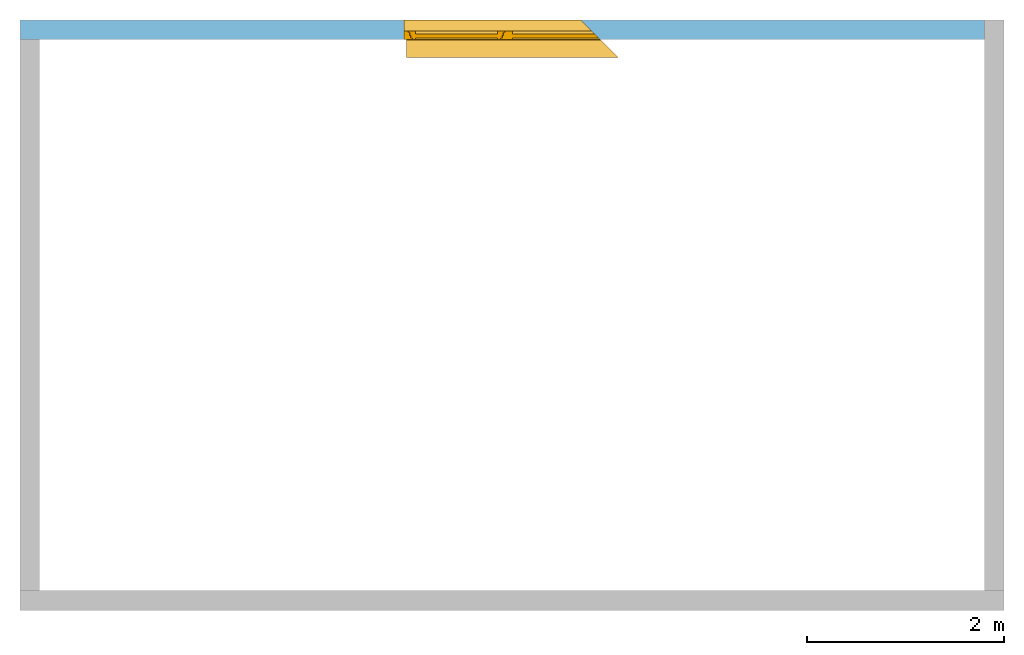
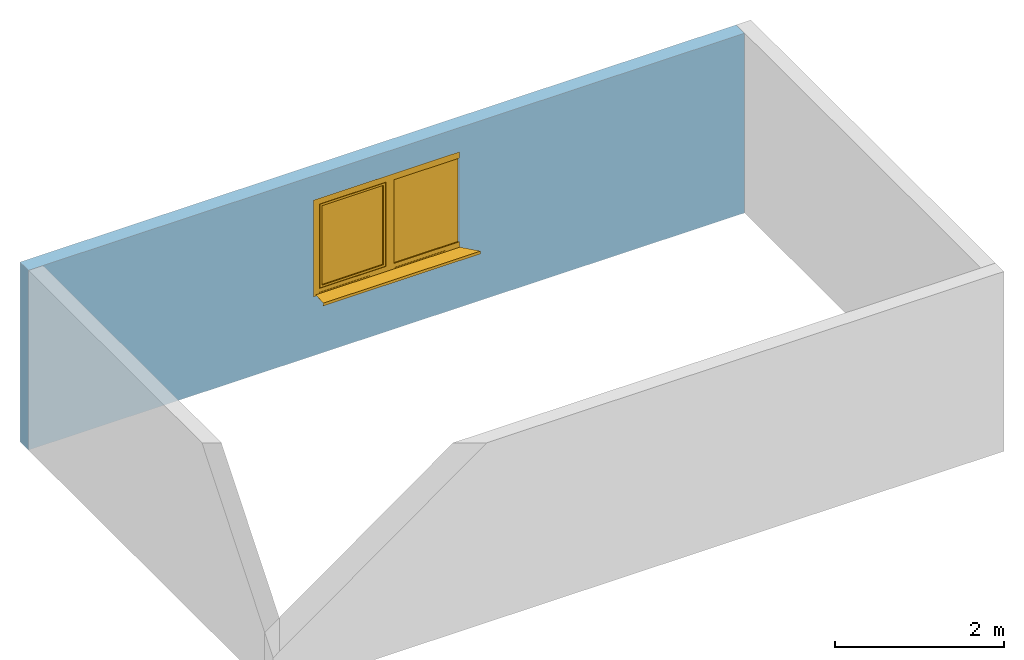
# One storey, part 2 of 2: 1 window, 1 opening, plus 1 element that does not belong to this part.
"""IFC2X3 building model written with IfcOpenShell, lengths in metres."""

from ifc_helpers import new_model, entity, si_unit, converted_unit, derived_unit, direction, frame, frame_2d, origin, place, context, subcontext, project, spatial, rectangle, extrude, faceted_brep, source, transform, mapped, material, material_list, layer, layer_set, layer_usage, type_object, type_shapes, element, fill, save


model = new_model("IFC2X3")

# Units and contexts
model_context = context("Model", 3, precision=1e-05, world=origin(), true_north=direction((6.12303176911189e-17, 1.0)))
body_context = subcontext(model_context, "Body", "Model", "MODEL_VIEW")
ifc_project = project(units=[si_unit("LENGTHUNIT", "METRE"), si_unit("AREAUNIT", "SQUARE_METRE"), si_unit("VOLUMEUNIT", "CUBIC_METRE"), converted_unit("PLANEANGLEUNIT", "DEGREE", entity("IfcRatioMeasure", 0.0174532925199433), si_unit("PLANEANGLEUNIT", "RADIAN"), dimensions=[0, 0, 0, 0, 0, 0, 0]), si_unit("MASSUNIT", "GRAM", prefix="KILO"), derived_unit("MASSDENSITYUNIT", [(si_unit("MASSUNIT", "GRAM", prefix="KILO"), 1), (si_unit("LENGTHUNIT", "METRE"), -3)]), si_unit("TIMEUNIT", "SECOND"), si_unit("FREQUENCYUNIT", "HERTZ"), si_unit("THERMODYNAMICTEMPERATUREUNIT", "DEGREE_CELSIUS"), derived_unit("THERMALTRANSMITTANCEUNIT", [(si_unit("MASSUNIT", "GRAM", prefix="KILO"), 1), (si_unit("THERMODYNAMICTEMPERATUREUNIT", "KELVIN"), -1), (si_unit("TIMEUNIT", "SECOND"), -3)]), derived_unit("VOLUMETRICFLOWRATEUNIT", [(si_unit("LENGTHUNIT", "METRE"), 3), (si_unit("TIMEUNIT", "SECOND"), -1)]), si_unit("ELECTRICCURRENTUNIT", "AMPERE"), si_unit("ELECTRICVOLTAGEUNIT", "VOLT"), si_unit("POWERUNIT", "WATT"), si_unit("FORCEUNIT", "NEWTON", prefix="KILO"), si_unit("ILLUMINANCEUNIT", "LUX"), si_unit("LUMINOUSFLUXUNIT", "LUMEN"), si_unit("LUMINOUSINTENSITYUNIT", "CANDELA"), derived_unit("USERDEFINED", [(si_unit("MASSUNIT", "GRAM", prefix="KILO"), -1), (si_unit("LENGTHUNIT", "METRE"), -2), (si_unit("TIMEUNIT", "SECOND"), 3), (si_unit("LUMINOUSFLUXUNIT", "LUMEN"), 1)]), derived_unit("LINEARVELOCITYUNIT", [(si_unit("LENGTHUNIT", "METRE"), 1), (si_unit("TIMEUNIT", "SECOND"), -1)]), si_unit("PRESSUREUNIT", "PASCAL"), derived_unit("USERDEFINED", [(si_unit("LENGTHUNIT", "METRE"), -2), (si_unit("MASSUNIT", "GRAM", prefix="KILO"), 1), (si_unit("TIMEUNIT", "SECOND"), -2)])], contexts=[model_context])

# Site, building, storey
site_placement = place(None, frame((4.52949330505959e-05, 1.90131286899941e-05, 0.0)))
site = spatial("IfcSite", under=ifc_project, at=site_placement, CompositionType="ELEMENT")
building_placement = place(site_placement, origin())
building = spatial("IfcBuilding", under=site, at=building_placement, CompositionType="ELEMENT")
storey_placement = place(building_placement, origin())
storey = spatial("IfcBuildingStorey", under=building, at=storey_placement, CompositionType="ELEMENT", Elevation=0.0)

# Wall, opening, window
ifc_material_1 = material(Name="Ortbeton - bewehrt Verputzt")
ifc_layer = layer(ifc_material_1, 0.2)
ifc_layer_set = layer_set([ifc_layer], Name="STB 200")
ifc_layer_usage = layer_usage(ifc_layer_set, "AXIS2", "NEGATIVE", 0.1)
wall_type = type_object("IfcWallType", Name="STB 200", PredefinedType="STANDARD", material=ifc_layer_set)
wall_placement = place(storey_placement, frame((9.79995470506695, 5.8999809868713, 0.0), z_axis=(0.0, 0.0, 1.0), x_axis=(-1.0, 0.0, 0.0)))
wall = element("IfcWallStandardCase", 1, at=wall_placement, inside=storey, type_object=wall_type, material=ifc_layer_usage, Name="STB 200", ObjectType="STB 200", context=body_context, shape_type="SweptSolid", body=[
    extrude(rectangle(XDim=9.79999999999999, YDim=0.2, at=frame_2d((4.9, 2.22044604925031e-16), x_axis=(-1.0, 0.0))), origin(), (0.0, 0.0, 1.0), 2.6),
])
opening_placement = place(wall_placement, frame((5.89999999999999, 0.260000000000955, 0.85), z_axis=(0.0, 0.0, 1.0), x_axis=(-1.0, 0.0, 0.0)))
opening = element("IfcOpeningElement", 2, at=opening_placement, cuts=wall, Name="STB 200", ObjectType="Opening", context=body_context, shape_type="Brep", body=[
    faceted_brep([(2.0, 0.159999999999999, 1.4), (1.79999999999903, 0.360000000000965, 1.4), (0.0, 0.360000000000971, 1.4), (0.0, 0.160000000000006, 1.4), (2.0, 0.159999999999999, 0.0), (0.0, 0.160000000000006, 0.0), (0.0, 0.360000000000971, 0.0), (1.79999999999903, 0.360000000000965, 0.0), (2.0, 0.159999999999998, 1.37000000000001), (2.15999999999993, 0.0, 1.37), (2.15999999999996, 0.0, 0.00999999999999922), (2.0, 0.159999999999997, 0.0200000000000026), (0.0299999999999997, 0.160000000000005, 0.0200000000000026), (0.0299999999999997, 0.160000000000005, 1.37000000000001), (0.0299999999999482, 0.0, 1.37), (0.0299999999999482, 0.0, 0.00999999999999922)], [[[0, 1, 2, 3]], [[4, 5, 6, 7]], [[0, 8, 9, 10, 11, 4, 7, 1]], [[1, 7, 6, 2]], [[2, 6, 5, 3]], [[3, 5, 4, 11, 12, 13, 8, 0]], [[14, 15, 10, 9]], [[14, 13, 12, 15]], [[15, 12, 11, 10]], [[9, 8, 13, 14]]]),
])
ifc_material_2 = material(Name="Kunststoff - grau 70-70-70")
ifc_material_3 = material(Name="Glas - Isolierverglasung klar")
ifc_material_4 = material()
ifc_material_list_1 = material_list([ifc_material_2, ifc_material_3, ifc_material_4])
ifc_material_list_2 = material_list([ifc_material_2, ifc_material_3, ifc_material_4])
window_style = type_object("IfcWindowStyle", Name="2000 x 1400", ConstructionType="NOTDEFINED", OperationType="NOTDEFINED", ParameterTakesPrecedence=False, Sizeable=False, material=ifc_material_list_2)
shared_shape = source(origin(), body_context, "Body", "Brep", [
    faceted_brep([(2.03999999999997, -0.250000000000002, 1.27999999999999), (2.03999999999997, -0.160000000000002, 1.27999999999999), (2.03999999999997, -0.160000000000002, 0.129999999999995), (2.03999999999997, -0.250000000000002, 0.129999999999995), (2.06999999999997, -0.160000000000006, 0.0999999999999949), (1.17499999999997, -0.160000000000006, 0.0999999999999978), (1.17499999999997, -0.160000000000002, 1.31), (2.06999999999997, -0.160000000000002, 1.30999999999999), (1.20499999999997, -0.160000000000002, 1.28), (1.20499999999997, -0.160000000000002, 0.129999999999998), (1.20499999999997, -0.250000000000002, 0.129999999999998), (1.20499999999997, -0.250000000000002, 1.28), (2.10999999999997, -0.250000000000002, 1.34999999999999), (1.13499999999997, -0.250000000000002, 1.35), (1.13499999999997, -0.250000000000002, 0.0599999999999977), (2.10999999999997, -0.250000000000002, 0.0599999999999946), (2.10999999999997, -0.235000000000002, 1.34999999999999), (2.10999999999997, -0.235000000000002, 0.0599999999999945), (1.13499999999997, -0.235000000000002, 0.0599999999999977), (1.13499999999997, -0.235000000000002, 1.35), (2.09499999999997, -0.235000000000002, 1.33499999999999), (1.14999999999997, -0.235000000000002, 1.335), (1.14999999999997, -0.235000000000002, 0.0749999999999978), (2.09499999999997, -0.235000000000002, 0.0749999999999945), (2.09499999999997, -0.205000000000002, 1.33499999999999), (2.09499999999997, -0.205000000000002, 0.0749999999999946), (1.14999999999997, -0.205000000000002, 0.0749999999999976), (1.14999999999997, -0.205000000000002, 1.335), (2.08499999999997, -0.205000000000002, 1.32499999999999), (1.15999999999997, -0.205000000000002, 1.325), (1.15999999999997, -0.205000000000002, 0.084999999999998), (2.08499999999996, -0.205000000000002, 0.0849999999999952), (2.08499999999997, -0.175000000000002, 1.32499999999999), (2.08499999999996, -0.175000000000002, 0.0849999999999953), (1.15999999999997, -0.175000000000002, 0.0849999999999983), (1.15999999999997, -0.175000000000002, 1.325), (2.06999999999997, -0.175000000000002, 1.30999999999999), (1.17499999999997, -0.175000000000002, 1.31), (1.17499999999997, -0.175000000000002, 0.0999999999999978), (2.06999999999997, -0.175000000000002, 0.0999999999999951)], [[[0, 1, 2, 3]], [[4, 5, 6, 7], [1, 8, 9, 2]], [[3, 2, 9, 10]], [[3, 10, 11, 0], [12, 13, 14, 15]], [[16, 12, 15, 17]], [[17, 15, 14, 18]], [[17, 18, 19, 16], [20, 21, 22, 23]], [[24, 20, 23, 25]], [[25, 23, 22, 26]], [[25, 26, 27, 24], [28, 29, 30, 31]], [[32, 28, 31, 33]], [[33, 31, 30, 34]], [[33, 34, 35, 32], [36, 37, 38, 39]], [[7, 36, 39, 4]], [[4, 39, 38, 5]], [[10, 9, 8, 11]], [[18, 14, 13, 19]], [[26, 22, 21, 27]], [[34, 30, 29, 35]], [[5, 38, 37, 6]], [[11, 8, 1, 0]], [[19, 13, 12, 16]], [[27, 21, 20, 24]], [[35, 29, 28, 32]], [[6, 37, 36, 7]]], outer=[[True], [True, False], [True], [False, True], [True], [True], [True, False], [True], [True], [True, False], [True], [True], [True, False], [True], [True], [True], [True], [True], [True], [True], [True], [True], [True], [True], [True]]),
    faceted_brep([(2.03999999999997, -0.175, 0.13000000000003), (2.03999999999997, -0.218999999999999, 0.13000000000003), (1.20499999999996, -0.218999999999999, 0.130000000000033), (1.20499999999996, -0.175, 0.130000000000033), (2.03999999999997, -0.175, 1.28), (2.03999999999997, -0.218999999999999, 1.28), (1.20499999999996, -0.218999999999999, 1.28000000000001), (1.20499999999996, -0.175, 1.28000000000001)], [[[0, 1, 2, 3]], [[4, 5, 1, 0]], [[5, 6, 2, 1]], [[6, 7, 3, 2]], [[7, 4, 0, 3]], [[4, 7, 6, 5]]]),
    faceted_brep([(-0.0220000000000309, 0.0220000000000022, 0.0106252434276902), (0.0, 0.0, 0.0120002434276901), (0.157999999999965, -0.157999999999998, 0.0218752434276897), (2.12999999999997, -0.157999999999998, 0.0218752434276897), (2.12999999999997, 0.0, 0.0120002434276901), (2.12999999999997, 0.0220000000000022, 0.0106252434276902), (-0.022000000000031, 0.0220000000000022, -0.0293747565723099), (2.12999999999997, 0.0220000000000022, -0.0293747565723099), (-0.010000000000031, 0.0100000000000022, -0.02937475657231), (2.12999999999997, 0.0100000000000021, -0.02937475657231), (-0.010000000000031, 0.0100000000000021, -0.02737475657231), (2.12999999999997, 0.0100000000000021, -0.02737475657231), (-0.0200000000000308, 0.020000000000002, -0.02737475657231), (2.12999999999997, 0.0200000000000023, -0.02737475657231), (-0.0200000000000309, 0.0200000000000023, 0.00875000000000018), (2.12999999999997, 0.0200000000000023, 0.00875000000000018), (0.0, 0.0, 0.0100000000000002), (2.12999999999997, 0.0, 0.0100000000000002), (2.12999999999997, -0.159999999999998, 0.0200000000000002), (0.159999999999965, -0.159999999999998, 0.0200000000000002), (0.159999999999965, -0.159999999999998, 0.0400000000000005), (2.12999999999997, -0.159999999999998, 0.0400000000000005), (0.157999999999965, -0.157999999999998, 0.0400000000000005), (2.12999999999997, -0.157999999999998, 0.0400000000000005)], [[[0, 1, 2, 3, 4, 5]], [[6, 0, 5, 7]], [[8, 6, 7, 9]], [[10, 8, 9, 11]], [[12, 10, 11, 13]], [[14, 12, 13, 15]], [[16, 14, 15, 17, 18, 19]], [[20, 19, 18, 21]], [[22, 20, 21, 23]], [[2, 22, 23, 3]], [[16, 1, 0, 6, 8, 10, 12, 14]], [[17, 4, 3, 23, 21, 18]], [[1, 16, 19, 20, 22, 2]], [[4, 17, 15, 13, 11, 9, 7, 5]]]),
    faceted_brep([(2.15999999999996, -0.16, 0.0), (2.15999999999996, -0.25, 0.0), (0.249999999999968, -0.25, 0.0), (0.159999999999968, -0.16, 0.0), (2.15999999999996, -0.16, 1.4), (2.15999999999996, -0.25, 1.4), (2.11499999999996, -0.25, 1.355), (2.11499999999996, -0.25, 0.0550000000000035), (1.12999999999996, -0.25, 0.0550000000000035), (1.12999999999996, -0.25, 1.355), (0.249999999999967, -0.25, 1.4), (0.249999999999967, -0.25, 1.30999999999999), (1.05499999999997, -0.25, 1.30999999999999), (1.05499999999997, -0.25, 0.100000000000001), (0.249999999999967, -0.25, 0.100000000000001), (0.159999999999968, -0.16, 1.4), (0.159999999999968, -0.16, 1.30999999999999), (2.07499999999996, -0.16, 0.0950000000000033), (2.07499999999996, -0.16, 1.315), (1.16999999999996, -0.16, 1.315), (1.16999999999996, -0.16, 0.0950000000000033), (0.159999999999968, -0.16, 0.100000000000001), (1.05499999999997, -0.16, 0.100000000000001), (1.05499999999997, -0.16, 1.30999999999999), (2.07499999999996, -0.175000000000004, 0.0950000000000033), (2.07499999999996, -0.175000000000004, 1.315), (1.16999999999996, -0.175000000000002, 0.0950000000000034), (1.16999999999996, -0.175000000000002, 1.315), (2.11499999999996, -0.235000000000004, 1.355), (2.11499999999996, -0.235000000000004, 0.0550000000000035), (1.12999999999996, -0.235000000000002, 0.0550000000000032), (1.12999999999996, -0.235000000000002, 1.355), (2.09999999999996, -0.235000000000004, 1.34), (2.09999999999996, -0.235000000000004, 0.0700000000000033), (1.14499999999996, -0.235000000000002, 0.0700000000000034), (1.14499999999996, -0.235000000000002, 1.34), (2.09999999999996, -0.205000000000003, 0.0700000000000036), (2.09999999999996, -0.205000000000003, 1.34), (1.14499999999996, -0.205000000000002, 1.34), (1.14499999999996, -0.205000000000002, 0.0700000000000039), (2.08999999999996, -0.205000000000003, 1.33), (2.08999999999996, -0.205000000000003, 0.0800000000000037), (1.15499999999996, -0.205000000000002, 0.080000000000004), (1.15499999999996, -0.205000000000002, 1.33), (2.08999999999996, -0.175000000000004, 0.0800000000000037), (2.08999999999996, -0.175000000000004, 1.33), (1.15499999999996, -0.175000000000002, 1.33), (1.15499999999996, -0.175000000000002, 0.0800000000000037)], [[[0, 1, 2, 3]], [[4, 5, 1, 0]], [[6, 7, 8, 9], [5, 10, 11, 12, 13, 14, 2, 1]], [[10, 15, 16, 11]], [[17, 18, 19, 20], [15, 4, 0, 3, 21, 22, 23, 16]], [[13, 22, 21, 14]], [[12, 23, 22, 13]], [[17, 24, 25, 18]], [[26, 20, 19, 27]], [[24, 17, 20, 26]], [[28, 29, 7, 6]], [[7, 29, 30, 8]], [[8, 30, 31, 9]], [[29, 28, 31, 30], [32, 33, 34, 35]], [[36, 37, 38, 39], [40, 41, 42, 43]], [[37, 36, 33, 32]], [[33, 36, 39, 34]], [[25, 24, 26, 27], [44, 45, 46, 47]], [[45, 44, 41, 40]], [[41, 44, 47, 42]], [[34, 39, 38, 35]], [[42, 47, 46, 43]], [[4, 15, 10, 5]], [[23, 12, 11, 16]], [[28, 6, 9, 31]], [[37, 32, 35, 38]], [[45, 40, 43, 46]], [[18, 25, 27, 19]], [[3, 2, 14, 21]]], outer=[[True], [True], [False, True], [True], [False, True], [True], [True], [True], [True], [True], [True], [True], [True], [True, False], [True, False], [True], [True], [False, True], [True], [True], [True], [True], [True], [True], [True], [True], [True], [True], [True]]),
    faceted_brep([(0.249999999999967, -0.25, 0.025), (0.360000000000932, -0.360000000000965, 0.025), (2.15999999999996, -0.360000000000965, 0.025), (2.15999999999996, -0.25, 0.025), (0.249999999999967, -0.25, 0.0), (2.15999999999996, -0.25, 0.0), (2.15999999999996, -0.350000000000965, 0.0), (0.350000000000932, -0.350000000000965, 0.0), (0.350000000000932, -0.350000000000965, 0.00700000000000003), (0.360000000000932, -0.360000000000965, 0.00700000000000003), (2.15999999999996, -0.360000000000965, 0.00700000000000003), (2.15999999999996, -0.350000000000965, 0.00700000000000003)], [[[0, 1, 2, 3]], [[4, 5, 6, 7]], [[1, 0, 4, 7, 8, 9]], [[2, 1, 9, 10]], [[3, 2, 10, 11, 6, 5]], [[0, 3, 5, 4]], [[8, 11, 10, 9]], [[11, 8, 7, 6]]]),
    faceted_brep([(1.05499999999996, -0.174999999999998, 0.100000000000001), (1.05499999999996, -0.218999999999998, 0.100000000000001), (0.218999999999969, -0.218999999999998, 0.100000000000004), (0.174999999999969, -0.174999999999998, 0.100000000000004), (1.05499999999997, -0.174999999999998, 1.30999999999999), (1.05499999999997, -0.218999999999998, 1.30999999999999), (0.218999999999973, -0.218999999999998, 1.31), (0.174999999999973, -0.174999999999998, 1.31)], [[[0, 1, 2, 3]], [[4, 5, 1, 0]], [[5, 6, 2, 1]], [[6, 7, 3, 2]], [[7, 4, 0, 3]], [[4, 7, 6, 5]]]),
])
type_shapes(window_style, [shared_shape])
window_placement = place(opening_placement, frame((2.15999999999996, 0.0, 0.0), z_axis=(0.0, 0.0, 1.0), x_axis=(-1.0, 0.0, 0.0)))
window = element("IfcWindow", 3, at=window_placement, inside=storey, type_object=window_style, material=ifc_material_list_1, Name="FE 2 tlg - 1 Nurglasecke-konfigurierbar:2000 x 1400", ObjectType="2000 x 1400", OverallHeight=2.25, OverallWidth=2.27527819818117, context=body_context, shape_type="MappedRepresentation", body=[
    mapped(shared_shape, transform((0.0, 0.0, 0.0), scale=1.0)),
])
fill(opening, window)

save(model, "model.ifc")
